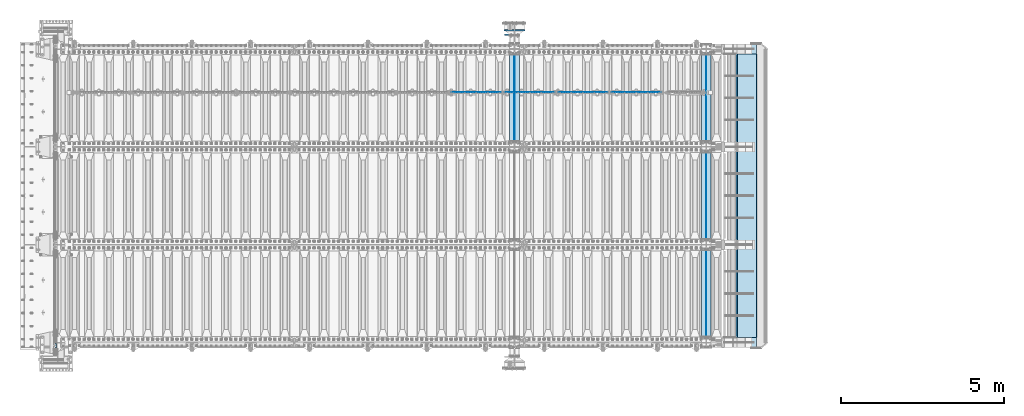
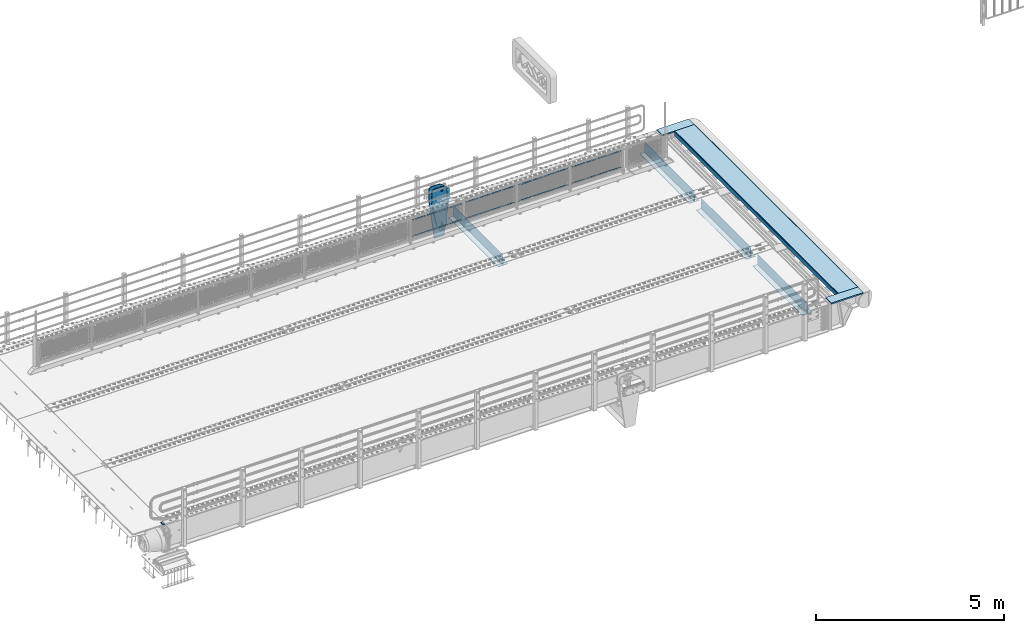
# One storey, part 213 of 270: 23 plates.
"""IFC2X3 building model written with IfcOpenShell, lengths in millimetres."""

from ifc_helpers import new_model, si_unit, frame, origin_with_axes, place, context, subcontext, project, spatial, faceted_brep, material, type_object, element, save


model = new_model("IFC2X3")

# Units and contexts
model_context = context("Model", 3, precision=1e-05, world=origin_with_axes())
body_context = subcontext(model_context, "Body", "Model", "MODEL_VIEW")
ifc_project = project(units=[si_unit("LENGTHUNIT", "METRE", prefix="MILLI"), si_unit("AREAUNIT", "SQUARE_METRE"), si_unit("VOLUMEUNIT", "CUBIC_METRE"), si_unit("MASSUNIT", "GRAM", prefix="KILO"), si_unit("TIMEUNIT", "SECOND"), si_unit("PLANEANGLEUNIT", "RADIAN"), si_unit("SOLIDANGLEUNIT", "STERADIAN"), si_unit("THERMODYNAMICTEMPERATUREUNIT", "DEGREE_CELSIUS"), si_unit("LUMINOUSINTENSITYUNIT", "LUMEN")], contexts=[model_context])

# Site, building, storey
site_placement = place(None, origin_with_axes())
site = spatial("IfcSite", under=ifc_project, at=site_placement, CompositionType="ELEMENT")
building_placement = place(site_placement, origin_with_axes())
building = spatial("IfcBuilding", under=site, at=building_placement, Name="Standard", CompositionType="ELEMENT")
storey_placement = place(building_placement, origin_with_axes())
storey = spatial("IfcBuildingStorey", under=building, at=storey_placement, Name="Undefined", CompositionType="ELEMENT", Elevation=0.0)

# Plates
ifc_material_1 = material()
plate_type_1 = type_object("IfcPlateType", PredefinedType="NOTDEFINED")
plate_1_placement = place(storey_placement, frame((-10.0000000600695, -24089.9999995683, -15.9997806105538), z_axis=(-1.0, 0.0, 0.0), x_axis=(0.0, -4.95099997756316e-06, 0.999999999987744)))
element("IfcPlate", 1, at=plate_1_placement, inside=storey, type_object=plate_type_1, material=ifc_material_1, context=body_context, shape_type="Brep", body=[
    faceted_brep([(1.77635683940025e-15, -60.0000000000073, 0.0), (-0.000933120085688799, -60.0000000000036, 60.0), (-0.000933120085688799, 59.9999999999964, 60.0), (-1.77635683940025e-15, 59.9999999999964, 0.0), (24.9991450303709, -60.0, 60.0), (24.9991450303709, 59.9999999999964, 60.0), (26.544215218168, -60.0000000000036, 59.7552873850884), (26.544215218168, 60.0, 59.7552873850884), (27.9380461396139, -60.0000000000036, 59.0451032459123), (27.9380461396139, 60.0, 59.0451032459123), (29.0442025908961, -60.0000000000036, 57.9389639895784), (29.0442025908961, 60.0, 57.9389639895784), (29.7544083969366, -60.0, 56.5451441080361), (29.7544083969366, 60.0000000000036, 56.5451441080361), (29.9991450297669, -60.0000000000036, 55.0000777244568), (29.9991450297669, 60.0, 55.0000777244568), (29.999922274335, -60.0, 5.00007772445705), (29.999922274335, 60.0, 5.00007772445704), (29.7552240705896, -60.0000000000036, 3.45497416452589), (29.7552240705896, 60.0, 3.45497416452589), (29.0450346578116, -60.0, 2.06111146690959), (29.0450346578116, 59.9999999999964, 2.0611114669096), (27.9388736885072, -60.0, 0.954933302319514), (27.9388736885072, 59.9999999999964, 0.954933302319516), (26.5450220308766, -60.0000000000036, 0.244722222183089), (26.5450220308766, 60.0, 0.244722222183091), (24.9999222749392, -60.0, 2.66453525910038e-13), (24.9999222749392, 60.0, 2.66453525910038e-13)], [[[0, 1, 2, 3]], [[1, 4, 5, 2]], [[4, 6, 7, 5]], [[6, 8, 9, 7]], [[8, 10, 11, 9]], [[10, 12, 13, 11]], [[12, 14, 15, 13]], [[14, 16, 17, 15]], [[16, 18, 19, 17]], [[18, 20, 21, 19]], [[20, 22, 23, 21]], [[22, 24, 25, 23]], [[24, 26, 27, 25]], [[26, 0, 3, 27]], [[5, 7, 9, 11, 13, 15, 17, 19, 21, 23, 25, 27, 3, 2]], [[26, 24, 22, 20, 18, 16, 14, 12, 10, 8, 6, 4, 1, 0]]]),
])
ifc_material_2 = material(Name="STEEL/S355N")
plate_type_2 = type_object("IfcPlateType", PredefinedType="NOTDEFINED")
for number, where, z_axis, x_axis in (
    (2, (19918.0, -15175.0, 0.0), (0.0, 0.0, -1.0), (0.0, -1.0, 0.0)),
    (3, (19918.0, -18175.0, 0.0), (0.0, 0.0, -1.0), (0.0, -1.0, 0.0)),
    (4, (19918.0, -21175.0, 0.0), (0.0, 0.0, -1.0), (0.0, -1.0, 0.0)),
    (5, (14035.0, -15175.0, 0.0), (0.0, 0.0, -1.0), (0.0, -1.0, 0.0)),
):
    element("IfcPlate", number, at=place(storey_placement, frame(where, z_axis=z_axis, x_axis=x_axis)), inside=storey, type_object=plate_type_2, material=ifc_material_2, context=body_context, shape_type="Brep", body=[
        faceted_brep([(0.0, -5.0, 0.0), (0.0, -5.0, 336.0), (0.0, 5.0, 336.0), (0.0, 5.0, 0.0), (2650.0, -5.0, 336.0), (2650.0, 5.0, 336.0), (2650.0, -5.0, 0.0), (2650.0, 5.0, 0.0)], [[[0, 1, 2, 3]], [[1, 4, 5, 2]], [[4, 6, 7, 5]], [[6, 0, 3, 7]], [[5, 7, 3, 2]], [[6, 4, 1, 0]]]),
    ])
plate_type_3 = type_object("IfcPlateType", PredefinedType="NOTDEFINED")
for number, where, z_axis, x_axis in (
    (6, (19768.0, -17825.0, -343.0), (0.0, 1.0, 0.0), (1.0, 0.0, 0.0)),
    (7, (19768.0, -20825.0, -343.0), (0.0, 1.0, 0.0), (1.0, 0.0, 0.0)),
    (8, (19768.0, -23825.0, -343.0), (0.0, 1.0, 0.0), (1.0, 0.0, 0.0)),
    (9, (13885.0, -17825.0, -343.0), (0.0, 1.0, 0.0), (1.0, 0.0, 0.0)),
):
    element("IfcPlate", number, at=place(storey_placement, frame(where, z_axis=z_axis, x_axis=x_axis)), inside=storey, type_object=plate_type_3, material=ifc_material_2, context=body_context, shape_type="Brep", body=[
        faceted_brep([(0.0, -7.0, 0.0), (0.0, -7.0, 2650.0), (0.0, 7.0, 2650.0), (0.0, 7.0, 0.0), (300.0, -7.0, 2650.0), (300.0, 7.0, 2650.0), (300.0, -7.0, 0.0), (300.0, 7.0, 0.0)], [[[0, 1, 2, 3]], [[1, 4, 5, 2]], [[4, 6, 7, 5]], [[6, 0, 3, 7]], [[5, 7, 3, 2]], [[6, 4, 1, 0]]]),
    ])
ifc_material_3 = material(Name="Misc_Undefined")
plate_type_4 = type_object("IfcPlateType", PredefinedType="NOTDEFINED")
plate_2_placement = place(storey_placement, frame((17004.5050117304, -16329.5, 351.520303374641), z_axis=(0.0, 0.0, 1.0), x_axis=(1.0, 0.0, 0.0)))
element("IfcPlate", 10, at=plate_2_placement, inside=storey, type_object=plate_type_4, material=ifc_material_3, context=body_context, shape_type="Brep", body=[
    faceted_brep([(0.0, -1.5, 0.0), (35.0002975463867, -1.5, 34.9996948242188), (35.0002975463867, 1.5, 34.9996948242188), (0.0, 1.5, 0.0), (1490.99035644531, -1.5, 34.9999923706055), (1490.99035644531, 1.5, 34.9999923706055), (1525.98999023438, -1.5, 2.81374923361e-11), (1525.98999023438, 1.5, 2.81374923361e-11)], [[[0, 1, 2, 3]], [[1, 4, 5, 2]], [[4, 6, 7, 5]], [[6, 0, 3, 7]], [[5, 7, 3, 2]], [[6, 4, 1, 0]]]),
])
plate_3_placement = place(storey_placement, frame((18530.5000001876, -16329.5, 914.520000175701), z_axis=(-0.707103624179499, 0.0, 0.707109938179501), x_axis=(-0.707109938179488, 0.0, -0.707103624179512)))
element("IfcPlate", 11, at=plate_3_placement, inside=storey, type_object=plate_type_4, material=ifc_material_3, context=body_context, shape_type="Brep", body=[
    faceted_brep([(0.0, -1.5, 0.0), (1079.04980468752, -1.5, 1079.04028320313), (1079.04980468752, 1.5, 1079.04028320313), (0.0, 1.5, 0.0), (1079.04272460939, -1.5, 1029.53576660156), (1079.04272460939, 1.5, 1029.53576660156), (49.4976959228497, -1.5, -7.27595761418343e-12), (49.4976959228497, 1.5, -7.27595761418343e-12)], [[[0, 1, 2, 3]], [[1, 4, 5, 2]], [[4, 6, 7, 5]], [[6, 0, 3, 7]], [[5, 7, 3, 2]], [[6, 4, 1, 0]]]),
])
plate_4_placement = place(storey_placement, frame((15371.5050117304, -16329.5, 351.520303374641), z_axis=(0.0, 0.0, 1.0), x_axis=(1.0, 0.0, 0.0)))
element("IfcPlate", 12, at=plate_4_placement, inside=storey, type_object=plate_type_4, material=ifc_material_3, context=body_context, shape_type="Brep", body=[
    faceted_brep([(0.0, -1.5, 0.0), (35.0002975463867, -1.5, 34.9996948242188), (35.0002975463867, 1.5, 34.9996948242188), (0.0, 1.5, 0.0), (1490.99035644531, -1.5, 34.9999923706055), (1490.99035644531, 1.5, 34.9999923706055), (1525.98999023438, -1.5, 2.81374923361e-11), (1525.98999023438, 1.5, 2.81374923361e-11)], [[[0, 1, 2, 3]], [[1, 4, 5, 2]], [[4, 6, 7, 5]], [[6, 0, 3, 7]], [[5, 7, 3, 2]], [[6, 4, 1, 0]]]),
])
plate_5_placement = place(storey_placement, frame((16897.5000001876, -16329.5, 914.520000175701), z_axis=(-0.707103624179499, 0.0, 0.707109938179501), x_axis=(-0.707109938179488, 0.0, -0.707103624179512)))
element("IfcPlate", 13, at=plate_5_placement, inside=storey, type_object=plate_type_4, material=ifc_material_3, context=body_context, shape_type="Brep", body=[
    faceted_brep([(0.0, -1.5, 0.0), (1079.04980468752, -1.5, 1079.04028320313), (1079.04980468752, 1.5, 1079.04028320313), (0.0, 1.5, 0.0), (1079.04272460939, -1.5, 1029.53576660156), (1079.04272460939, 1.5, 1029.53576660156), (49.4976959228497, -1.5, -7.27595761418343e-12), (49.4976959228497, 1.5, -7.27595761418343e-12)], [[[0, 1, 2, 3]], [[1, 4, 5, 2]], [[4, 6, 7, 5]], [[6, 0, 3, 7]], [[5, 7, 3, 2]], [[6, 4, 1, 0]]]),
])
plate_6_placement = place(storey_placement, frame((13738.5050117304, -16329.5, 351.520303374641), z_axis=(0.0, 0.0, 1.0), x_axis=(1.0, 0.0, 0.0)))
element("IfcPlate", 14, at=plate_6_placement, inside=storey, type_object=plate_type_4, material=ifc_material_3, context=body_context, shape_type="Brep", body=[
    faceted_brep([(0.0, -1.5, 0.0), (35.0002975463867, -1.5, 34.9996948242188), (35.0002975463867, 1.5, 34.9996948242188), (0.0, 1.5, 0.0), (1490.99035644531, -1.5, 34.9999923706055), (1490.99035644531, 1.5, 34.9999923706055), (1525.98999023438, -1.5, 2.81374923361e-11), (1525.98999023438, 1.5, 2.81374923361e-11)], [[[0, 1, 2, 3]], [[1, 4, 5, 2]], [[4, 6, 7, 5]], [[6, 0, 3, 7]], [[5, 7, 3, 2]], [[6, 4, 1, 0]]]),
])
plate_7_placement = place(storey_placement, frame((15264.5000001876, -16329.5, 914.520000175701), z_axis=(-0.707103624179499, 0.0, 0.707109938179501), x_axis=(-0.707109938179488, 0.0, -0.707103624179512)))
element("IfcPlate", 15, at=plate_7_placement, inside=storey, type_object=plate_type_4, material=ifc_material_3, context=body_context, shape_type="Brep", body=[
    faceted_brep([(0.0, -1.5, 0.0), (1079.04980468752, -1.5, 1079.04028320313), (1079.04980468752, 1.5, 1079.04028320313), (0.0, 1.5, 0.0), (1079.04272460939, -1.5, 1029.53576660156), (1079.04272460939, 1.5, 1029.53576660156), (49.4976959228497, -1.5, -7.27595761418343e-12), (49.4976959228497, 1.5, -7.27595761418343e-12)], [[[0, 1, 2, 3]], [[1, 4, 5, 2]], [[4, 6, 7, 5]], [[6, 0, 3, 7]], [[5, 7, 3, 2]], [[6, 4, 1, 0]]]),
])
plate_8_placement = place(storey_placement, frame((12105.5050117304, -16329.5, 351.520303374641), z_axis=(0.0, 0.0, 1.0), x_axis=(1.0, 0.0, 0.0)))
element("IfcPlate", 16, at=plate_8_placement, inside=storey, type_object=plate_type_4, material=ifc_material_3, context=body_context, shape_type="Brep", body=[
    faceted_brep([(0.0, -1.5, 0.0), (35.0002975463867, -1.5, 34.9996948242188), (35.0002975463867, 1.5, 34.9996948242188), (0.0, 1.5, 0.0), (1490.99035644531, -1.5, 34.9999923706055), (1490.99035644531, 1.5, 34.9999923706055), (1525.98999023438, -1.5, 2.81374923361e-11), (1525.98999023438, 1.5, 2.81374923361e-11)], [[[0, 1, 2, 3]], [[1, 4, 5, 2]], [[4, 6, 7, 5]], [[6, 0, 3, 7]], [[5, 7, 3, 2]], [[6, 4, 1, 0]]]),
])
plate_9_placement = place(storey_placement, frame((13631.5000001876, -16329.5, 914.520000175701), z_axis=(-0.707103624179499, 0.0, 0.707109938179501), x_axis=(-0.707109938179488, 0.0, -0.707103624179512)))
element("IfcPlate", 17, at=plate_9_placement, inside=storey, type_object=plate_type_4, material=ifc_material_3, context=body_context, shape_type="Brep", body=[
    faceted_brep([(0.0, -1.5, 0.0), (1079.04980468752, -1.5, 1079.04028320313), (1079.04980468752, 1.5, 1079.04028320313), (0.0, 1.5, 0.0), (1079.04272460939, -1.5, 1029.53576660156), (1079.04272460939, 1.5, 1029.53576660156), (49.4976959228497, -1.5, -7.27595761418343e-12), (49.4976959228497, 1.5, -7.27595761418343e-12)], [[[0, 1, 2, 3]], [[1, 4, 5, 2]], [[4, 6, 7, 5]], [[6, 0, 3, 7]], [[5, 7, 3, 2]], [[6, 4, 1, 0]]]),
])
plate_type_5 = type_object("IfcPlateType", PredefinedType="NOTDEFINED")
for number, where, z_axis, x_axis in (
    (18, (20469.9988298906, -23850.0, -10.0000000000094), (1.0, 0.0, 0.0), (0.0, -1.0, 0.0)),
    (19, (20469.9988298905, -14850.0, -10.0000000004865), (1.0, 0.0, 0.0), (0.0, -1.0, 0.0)),
):
    element("IfcPlate", number, at=place(storey_placement, frame(where, z_axis=z_axis, x_axis=x_axis)), inside=storey, type_object=plate_type_5, material=ifc_material_2, context=body_context, shape_type="Brep", body=[
        faceted_brep([(300.0, 7.0, 986.0), (300.0, 20.0, 956.0), (-3.63797880709171e-11, 20.0, 956.0), (-3.63797880709171e-11, 7.0, 986.0), (0.0, 20.0, 0.0), (0.0, -20.0, 0.0), (-3.63797880709171e-11, -20.0, 986.0), (300.0, -20.0, 986.0), (300.0, -20.0, -1.81898940354586e-12), (300.0, 20.0, -1.81898940354586e-12)], [[[0, 1, 2, 3]], [[4, 5, 6, 3, 2]], [[6, 7, 0, 3]], [[7, 8, 9, 1, 0]], [[8, 5, 4, 9]], [[9, 4, 2, 1]], [[8, 7, 6, 5]]]),
    ])
plate_type_6 = type_object("IfcPlateType", PredefinedType="NOTDEFINED")
plate_10_placement = place(storey_placement, frame((14194.9999999931, -14559.9999999546, -955.000018205629), z_axis=(-0.901283188008788, 0.0, 0.433230441004225), x_axis=(-0.433230441004224, 0.0, -0.901283188008789)))
element("IfcPlate", 20, at=plate_10_placement, inside=storey, type_object=plate_type_6, material=ifc_material_2, context=body_context, shape_type="Brep", body=[
    faceted_brep([(-929.368911797764, -15.0000000000073, 583.252555031773), (-929.368911797764, 14.9999999999927, 583.252555031773), (-937.308302015211, 14.9999999999927, 596.68950330655), (-937.308302015211, -15.0000000000073, 596.68950330655), (-939.501244651427, 14.9999999999927, 612.141897896327), (-939.501244651427, -15.0000000000073, 612.141897896327), (-935.613884069124, 14.9999999999927, 627.257251801115), (-935.613884069124, -15.0000000000073, 627.257251801115), (-926.238035677944, 14.9999999999927, 639.734389409938), (-926.238035677944, -15.0000000000073, 639.734389409938), (-912.801087403169, 14.9999999999927, 647.673779627385), (-912.801087403169, -15.0000000000073, 647.673779627385), (-897.348692813393, 14.9999999999927, 649.866722263601), (-897.348692813393, -15.0000000000073, 649.866722263601), (-882.233338908602, 14.9999999999927, 645.979361681297), (-882.233338908602, -15.0000000000073, 645.979361681297), (-869.75620129978, 14.9999999999927, 636.603513290118), (-869.75620129978, -15.0000000000073, 636.603513290118), (-861.816811082333, 14.9999999999927, 623.166565015343), (-861.816811082333, -15.0000000000073, 623.166565015343), (-859.623868446117, 14.9999999999927, 607.714170425566), (-859.623868446117, -15.0000000000073, 607.714170425566), (-863.511229028421, 14.9999999999927, 592.598816520776), (-863.511229028421, -15.0000000000073, 592.598816520776), (-872.8870774196, 14.9999999999927, 580.121678911955), (-872.8870774196, -15.0000000000073, 580.121678911955), (-886.324025694375, 14.9999999999927, 572.182288694508), (-886.324025694375, -15.0000000000073, 572.182288694508), (-901.776420284151, 14.9999999999927, 569.98934605829), (-901.776420284151, -15.0000000000073, 569.98934605829), (-916.891774188941, 14.9999999999927, 573.876706640594), (-916.891774188941, -15.0000000000073, 573.876706640594), (264.349945979715, -15.0, 42.1349880284361), (264.349945979715, 15.0, 42.1349880284361), (15.595783730354, 14.9999999999927, 161.706590879499), (15.595783730354, -15.0000000000055, 161.706590879499), (244.096420288086, -15.0, -5.45696821063757e-11), (244.096420288086, 15.0, -5.45696821063757e-11), (0.0, -15.0, 0.0), (0.0, 15.0, 0.0), (-976.801696777344, -15.0, 469.530822753904), (-976.801696777344, 15.0, 469.530822753904), (-1005.61097945758, -15.0, 584.572341407271), (-1005.61097945758, 15.0, 584.572341407271), (-1008.62086606962, -15.0, 603.379087420497), (-1008.62086606962, 15.0, 603.379087420497), (-1008.34154488138, -15.0, 622.423117789542), (-1008.34154488138, 15.0, 622.423117789542), (-1004.7813898293, -15.0, 641.133500175492), (-1004.7813898293, 15.0, 641.133500175492), (-998.04713292392, -15.0, 658.949304871174), (-998.04713292392, 15.0, 658.949304871174), (-903.392995239108, -15.0, 855.865677422371), (-903.392995239108, 15.0, 855.865677422371), (-891.965893301475, -15.0, 873.346258360978), (-891.965893301475, 15.0, 873.346258360978), (-876.403853384474, -15.0, 887.273651594), (-876.403853384474, 15.0, 887.273651594), (-857.767402657617, -15.0, 896.698728408073), (-857.767402657617, 15.0, 896.698728408073), (-837.326584280019, -15.0, 900.979185474776), (-837.326584280019, 15.0, 900.979185474776), (-816.474406068865, -15.0, 899.823316755488), (-816.474406068865, 15.0, 899.823316755488), (-796.631909330703, -15.0, 893.309892783487), (-796.631909330703, 15.0, 893.309892783487), (-427.105804443359, -15.0, 715.685424804686), (-427.105804443359, 15.0, 715.685424804686), (138.633743286133, -15.0, 288.410614013672), (138.633743286133, 15.0, 288.410614013672), (291.101928710938, -15.0, 97.7892227172833), (291.101928710938, 15.0, 97.7892227172833), (270.84840339248, -15.0, 55.6542354651265), (270.84840339248, 15.0, 55.6542354651265), (22.0942403454173, -15.0000000000055, 175.225838699631), (22.0942403454173, 14.9999999999927, 175.225838699631), (-855.850321914575, -15.0, 588.916357782986), (-852.143242456357, -15.0, 592.234043554756), (-847.17598332599, -15.0, 591.958700638515), (-843.858297554222, -15.0, 588.251621180299), (-844.133640470461, -15.0, 583.284362049932), (-847.840719928679, -15.0, 579.966676278164), (-852.807979059045, -15.0, 580.2420191944), (-856.125664830814, -15.0, 583.94909865262), (-844.133640470461, 15.0, 583.284362049932), (-847.840719928679, 15.0, 579.966676278164), (-843.858297554222, 15.0, 588.251621180299), (-847.17598332599, 15.0, 591.958700638515), (-852.143242456357, 15.0, 592.234043554756), (-855.850321914575, 15.0, 588.916357782986), (-856.125664830814, 15.0, 583.94909865262), (-852.807979059045, 15.0, 580.2420191944)], [[[0, 1, 2, 3]], [[3, 2, 4, 5]], [[5, 4, 6, 7]], [[7, 6, 8, 9]], [[9, 8, 10, 11]], [[11, 10, 12, 13]], [[13, 12, 14, 15]], [[15, 14, 16, 17]], [[17, 16, 18, 19]], [[19, 18, 20, 21]], [[21, 20, 22, 23]], [[23, 22, 24, 25]], [[25, 24, 26, 27]], [[27, 26, 28, 29]], [[29, 28, 30, 31]], [[31, 30, 1, 0]], [[32, 33, 34, 35]], [[36, 37, 33, 32]], [[36, 38, 39, 37]], [[38, 40, 41, 39]], [[40, 42, 43, 41]], [[42, 44, 45, 43]], [[44, 46, 47, 45]], [[46, 48, 49, 47]], [[48, 50, 51, 49]], [[50, 52, 53, 51]], [[52, 54, 55, 53]], [[54, 56, 57, 55]], [[56, 58, 59, 57]], [[58, 60, 61, 59]], [[60, 62, 63, 61]], [[62, 64, 65, 63]], [[64, 66, 67, 65]], [[66, 68, 69, 67]], [[68, 70, 71, 69]], [[71, 70, 72, 73]], [[74, 75, 73, 72]], [[35, 34, 75, 74]], [[72, 70, 68, 66, 64, 62, 60, 58, 56, 54, 52, 50, 48, 46, 44, 42, 40, 38, 36, 32, 35, 74], [3, 5, 7, 9, 11, 13, 15, 17, 19, 21, 23, 25, 27, 29, 31, 0], [76, 77, 78, 79, 80, 81, 82, 83]], [[80, 84, 85, 81]], [[79, 86, 84, 80]], [[78, 87, 86, 79]], [[77, 88, 87, 78]], [[76, 89, 88, 77]], [[83, 90, 89, 76]], [[82, 91, 90, 83]], [[81, 85, 91, 82]], [[37, 39, 41, 43, 45, 47, 49, 51, 53, 55, 57, 59, 61, 63, 65, 67, 69, 71, 73, 75, 34, 33], [26, 24, 22, 20, 18, 16, 14, 12, 10, 8, 6, 4, 2, 1, 30, 28], [84, 86, 87, 88, 89, 90, 91, 85]]]),
])
plate_type_7 = type_object("IfcPlateType", PredefinedType="NOTDEFINED")
plate_11_placement = place(storey_placement, frame((14184.9999999931, -14419.9999999546, -1480.00001820563), z_axis=(0.0, 0.0, 1.0), x_axis=(-1.0, 0.0, 0.0)))
element("IfcPlate", 21, at=plate_11_placement, inside=storey, type_object=plate_type_7, material=ifc_material_2, context=body_context, shape_type="Brep", body=[
    faceted_brep([(145.403805922693, -15.0, 1549.59619407771), (145.403805922693, 15.0, 1549.59619407771), (150.000000000406, 15.0, 1551.5), (150.000000000406, -15.0, 1551.5), (154.596194078118, 15.0, 1549.59619407771), (154.596194078118, -15.0, 1549.59619407771), (156.500000000406, 15.0, 1545.0), (156.500000000406, -15.0, 1545.0), (154.596194078118, 15.0, 1540.40380592229), (154.596194078118, -15.0, 1540.40380592229), (150.000000000406, 15.0, 1538.5), (150.000000000406, -15.0, 1538.5), (145.403805922693, 15.0, 1540.40380592229), (145.403805922693, -15.0, 1540.40380592229), (143.500000000406, 15.0, 1545.0), (143.500000000406, -15.0, 1545.0), (300.0, -15.0, 0.0), (0.0, -15.0, 0.0), (0.0, 15.0, 0.0), (300.0, 15.0, 0.0), (462.5, -15.0, 1210.0), (462.5, 15.0, 1210.0), (462.5, -15.0, 1630.0), (462.5, 15.0, 1630.0), (459.774066103126, -15.0, 1650.7055236082), (459.774066103126, 15.0, 1650.7055236082), (451.782032302755, -15.0, 1670.0), (451.782032302755, 15.0, 1670.0), (439.068542494924, -15.0, 1686.56854249492), (439.068542494924, 15.0, 1686.56854249492), (422.5, -15.0, 1699.28203230276), (422.5, 15.0, 1699.28203230276), (403.205523608201, -15.0, 1707.27406610313), (403.205523608201, 15.0, 1707.27406610313), (382.5, -15.0, 1710.0), (382.5, 15.0, 1710.0), (151.788081037079, -15.0, 1710.0), (151.788081037079, 15.0, 1710.0), (132.694887325031, -15.0, 1708.33028179541), (132.694887325031, 15.0, 1708.33028179541), (114.181334578885, -15.0, 1703.37181734316), (114.181334578885, 15.0, 1703.37181734316), (96.8094667268542, -15.0, 1695.27513824985), (96.8094667268542, 15.0, 1695.27513824985), (81.1066678416755, -15.0, 1684.28604765144), (81.1066678416755, 15.0, 1684.28604765144), (-162.5, -15.0, 1480.0), (-162.5, 15.0, 1480.0), (-162.5, -15.0, 1210.0), (-162.5, 15.0, 1210.0), (121.715728752944, -15.0, 1628.28427124746), (134.692662705802, -15.0, 1636.95518130045), (150.000000000406, -15.0, 1640.0), (165.307337295009, -15.0, 1636.95518130045), (178.284271247867, -15.0, 1628.28427124746), (186.955181300857, -15.0, 1615.3073372946), (190.000000000406, -15.0, 1600.0), (186.955181300857, -15.0, 1584.6926627054), (178.284271247867, -15.0, 1571.71572875254), (165.307337295009, -15.0, 1563.04481869955), (150.000000000406, -15.0, 1560.0), (134.692662705802, -15.0, 1563.04481869955), (121.715728752944, -15.0, 1571.71572875254), (113.044818699955, -15.0, 1584.6926627054), (110.000000000406, -15.0, 1600.0), (113.044818699955, -15.0, 1615.3073372946), (121.715728752944, 14.9999999999527, 1571.71572875254), (113.044818699955, 14.9999999999527, 1584.6926627054), (134.692662705802, 14.9999999999527, 1563.04481869955), (150.000000000406, 14.9999999999527, 1560.0), (165.307337295009, 14.9999999999527, 1563.04481869955), (178.284271247867, 14.9999999999527, 1571.71572875254), (186.955181300857, 14.9999999999527, 1584.6926627054), (190.000000000406, 14.9999999999527, 1600.0), (186.955181300857, 14.9999999999527, 1615.3073372946), (178.284271247867, 14.9999999999527, 1628.28427124746), (165.307337295009, 14.9999999999527, 1636.95518130045), (150.000000000406, 14.9999999999527, 1640.0), (134.692662705802, 14.9999999999527, 1636.95518130045), (121.715728752944, 14.9999999999527, 1628.28427124746), (113.044818699955, 14.9999999999527, 1615.3073372946), (110.000000000406, 14.9999999999527, 1600.0)], [[[0, 1, 2, 3]], [[3, 2, 4, 5]], [[5, 4, 6, 7]], [[7, 6, 8, 9]], [[9, 8, 10, 11]], [[11, 10, 12, 13]], [[13, 12, 14, 15]], [[15, 14, 1, 0]], [[16, 17, 18, 19]], [[20, 16, 19, 21]], [[22, 20, 21, 23]], [[24, 22, 23, 25]], [[26, 24, 25, 27]], [[28, 26, 27, 29]], [[30, 28, 29, 31]], [[32, 30, 31, 33]], [[34, 32, 33, 35]], [[36, 34, 35, 37]], [[38, 36, 37, 39]], [[40, 38, 39, 41]], [[42, 40, 41, 43]], [[44, 42, 43, 45]], [[46, 44, 45, 47]], [[48, 46, 47, 49]], [[17, 48, 49, 18]], [[16, 20, 22, 24, 26, 28, 30, 32, 34, 36, 38, 40, 42, 44, 46, 48, 17], [3, 5, 7, 9, 11, 13, 15, 0], [50, 51, 52, 53, 54, 55, 56, 57, 58, 59, 60, 61, 62, 63, 64, 65]], [[62, 66, 67, 63]], [[61, 68, 66, 62]], [[60, 69, 68, 61]], [[59, 70, 69, 60]], [[58, 71, 70, 59]], [[57, 72, 71, 58]], [[56, 73, 72, 57]], [[55, 74, 73, 56]], [[54, 75, 74, 55]], [[53, 76, 75, 54]], [[52, 77, 76, 53]], [[51, 78, 77, 52]], [[50, 79, 78, 51]], [[65, 80, 79, 50]], [[64, 81, 80, 65]], [[63, 67, 81, 64]], [[47, 45, 43, 41, 39, 37, 35, 33, 31, 29, 27, 25, 23, 21, 19, 18, 49], [10, 8, 6, 4, 2, 1, 14, 12], [66, 68, 69, 70, 71, 72, 73, 74, 75, 76, 77, 78, 79, 80, 81, 67]]]),
])
plate_type_8 = type_object("IfcPlateType", PredefinedType="NOTDEFINED")
plate_12_placement = place(storey_placement, frame((20863.5545510642, -15149.9999999984, -155.274111776634), z_axis=(0.0, -1.0, 0.0), x_axis=(-0.0871556999853744, 0.0, 0.99619470183296)))
element("IfcPlate", 22, at=plate_12_placement, inside=storey, type_object=plate_type_8, material=ifc_material_2, context=body_context, shape_type="Brep", body=[
    faceted_brep([(0.0, -10.0, 0.0), (0.0, -9.99999999999636, 8700.0), (-2.27373675443232e-13, 9.99999999999636, 8700.0), (0.0, 10.0, 0.0), (155.0, -10.0, 8700.0), (155.0, 10.0, 8700.0), (155.0, -10.0, 0.0), (155.0, 10.0, 0.0)], [[[0, 1, 2, 3]], [[1, 4, 5, 2]], [[4, 6, 7, 5]], [[6, 0, 3, 7]], [[5, 7, 3, 2]], [[6, 4, 1, 0]]]),
])
plate_type_9 = type_object("IfcPlateType", PredefinedType="NOTDEFINED")
plate_13_placement = place(storey_placement, frame((20860.002968026, -15149.9999999984, 0.00398537333359705), z_axis=(0.999999999980065, 4.25000000169061e-07, -6.29999999987441e-06), x_axis=(0.0, -1.0, 0.0)))
element("IfcPlate", 23, at=plate_13_placement, inside=storey, type_object=plate_type_9, material=ifc_material_2, context=body_context, shape_type="Brep", body=[
    faceted_brep([(8700.0, -10.0, 596.995666503903), (8700.0, -5.49560397189452e-13, 616.995666503903), (6.7275379478815e-05, -5.47284439988971e-13, 616.995788574215), (6.50946403766284e-05, -10.0, 596.995788574219), (6.7275379478815e-05, 10.0, 616.995788574215), (0.0, 10.0, 0.0), (0.0, -10.0, 0.0), (8700.0, 10.0, 616.995666503903), (8700.0, -10.0, -3.28509486280382e-09), (8700.0, 10.0, -3.28145688399673e-09)], [[[0, 1, 2, 3]], [[4, 5, 6, 3, 2]], [[7, 4, 2, 1]], [[8, 9, 7, 1, 0]], [[8, 6, 5, 9]], [[7, 9, 5, 4]], [[6, 8, 0, 3]]]),
])

save(model, "model.ifc")
